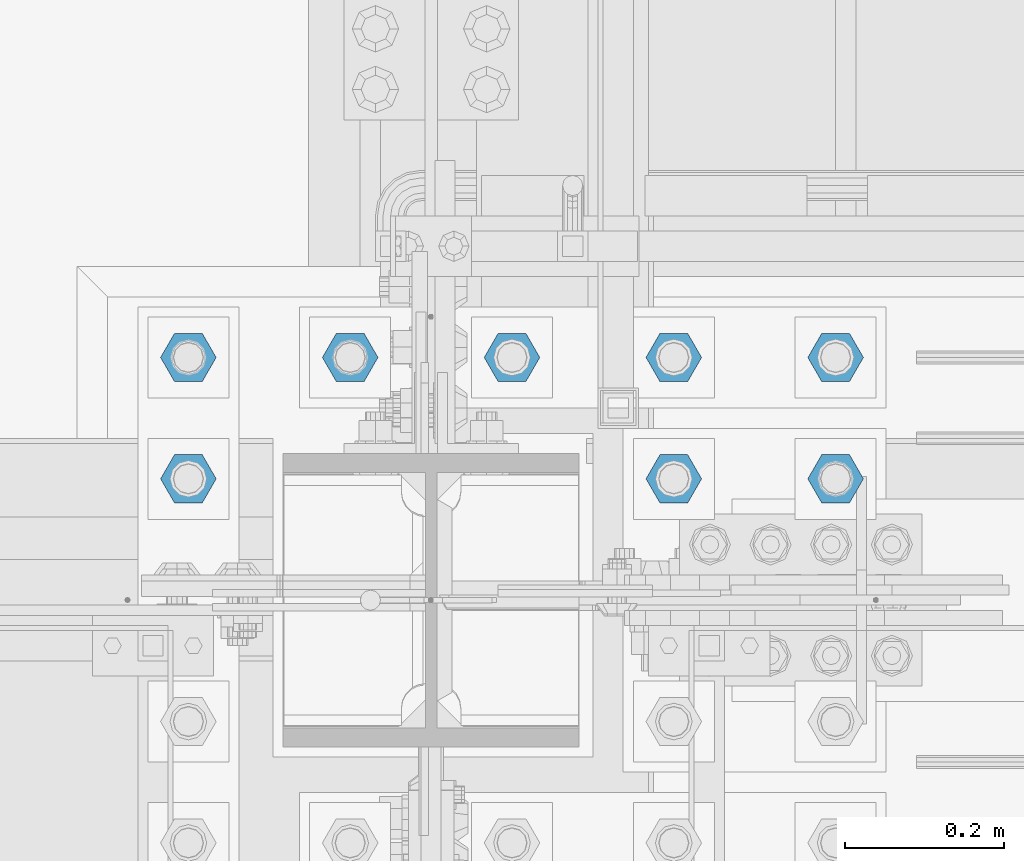
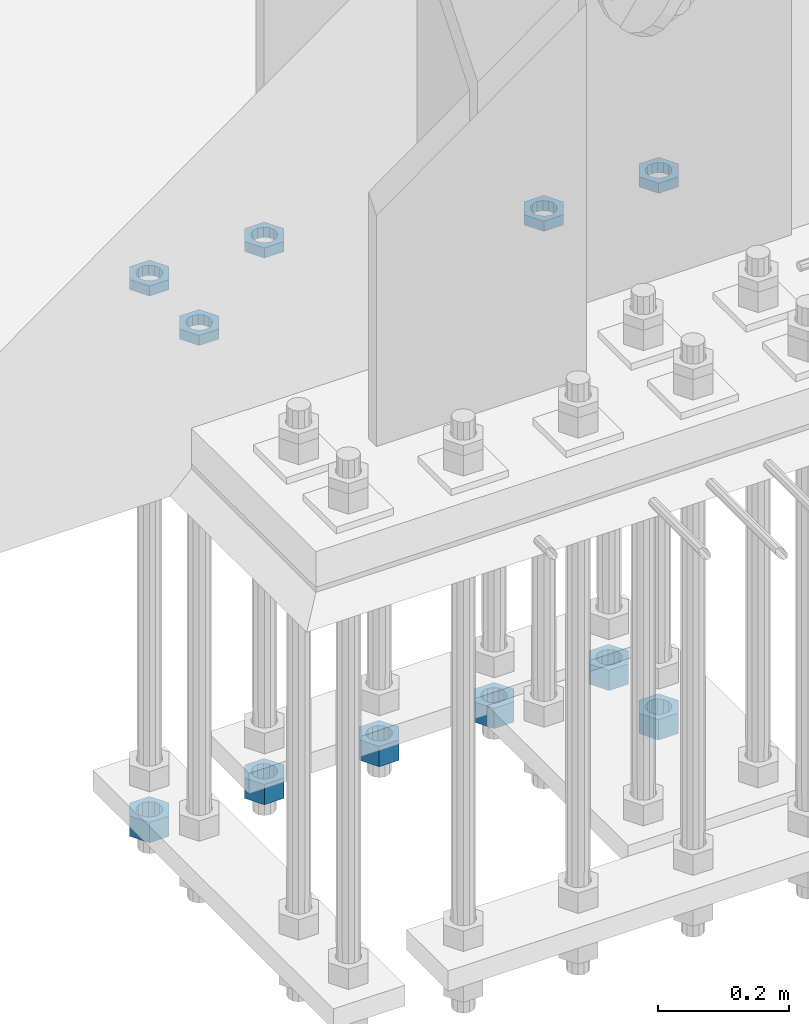
# One storey, part 2828 of 3843: 11 beams, 1 element without a shape of its own.
"""IFC2X3 building model written with IfcOpenShell, lengths in millimetres."""

from ifc_helpers import new_model, si_unit, frame, origin_with_axes, place, context, subcontext, project, spatial, faceted_brep, material, type_object, element, aggregate, save


model = new_model("IFC2X3")

# Units and contexts
model_context = context("Model", 3, precision=1e-05, world=origin_with_axes())
body_context = subcontext(model_context, "Body", "Model", "MODEL_VIEW")
ifc_project = project(units=[si_unit("LENGTHUNIT", "METRE", prefix="MILLI"), si_unit("AREAUNIT", "SQUARE_METRE"), si_unit("VOLUMEUNIT", "CUBIC_METRE"), si_unit("MASSUNIT", "GRAM", prefix="KILO"), si_unit("TIMEUNIT", "SECOND"), si_unit("PLANEANGLEUNIT", "RADIAN"), si_unit("SOLIDANGLEUNIT", "STERADIAN"), si_unit("THERMODYNAMICTEMPERATUREUNIT", "DEGREE_CELSIUS"), si_unit("LUMINOUSINTENSITYUNIT", "LUMEN")], contexts=[model_context])

# Site, building, storey
site_placement = place(None, origin_with_axes())
site = spatial("IfcSite", under=ifc_project, at=site_placement, CompositionType="ELEMENT")
building_placement = place(site_placement, origin_with_axes())
building = spatial("IfcBuilding", under=site, at=building_placement, Name="Undefined", CompositionType="ELEMENT")
storey_placement = place(building_placement, origin_with_axes())
storey = spatial("IfcBuildingStorey", under=building, at=storey_placement, Name="Undefined", CompositionType="ELEMENT", Elevation=0.0)

# Assembly, beams
assembly_placement = place(storey_placement, origin_with_axes())
assembly = element("IfcElementAssembly", 1, at=assembly_placement, inside=storey, Name="TEMPLATE", AssemblyPlace="NOTDEFINED", PredefinedType="RIGID_FRAME")
ifc_material = material(Name="STEEL/A572-50")
beam_type_1 = type_object("IfcBeamType", Name="1-1/2_HEAVY_HEX_NUT", PredefinedType="NOTDEFINED")
beam_1_placement = place(assembly_placement, frame((56438.8, 25768.3, 28746.4500015259), z_axis=(0.0, 1.0, 0.0), x_axis=(0.0, 0.0, -1.0)))
beam_1 = element("IfcBeam", 2, at=beam_1_placement, type_object=beam_type_1, material=ifc_material, Name="NUT", ObjectType="1-1/2_HEAVY_HEX_NUT", context=body_context, shape_type="Brep", body=[
    faceted_brep([(0.0, -34.9199981689453, 0.0), (0.0, -17.4599990844727, -30.25), (38.0999999999985, -17.4599990844727, -30.25), (38.0999999999985, -34.9199981689453, 0.0), (0.0, 17.4599990844727, -30.25), (38.0999999999985, 17.4599990844727, -30.25), (0.0, 34.9199981689453, 0.0), (38.0999999999985, 34.9199981689453, 0.0), (0.0, 17.4599990844727, 30.25), (38.0999999999985, 17.4599990844727, 30.25), (0.0, -17.4599990844727, 30.25), (38.0999999999985, -17.4599990844727, 30.25), (0.0, 0.0, 20.6399993896484), (0.0, 8.9553601105581, 18.5959968835959), (38.0999999999985, 8.9553601105581, 18.5959968835959), (38.0999999999985, 0.0, 20.6399993896484), (0.0, 16.1370013209525, 12.8688291298167), (38.0999999999985, 16.1370013209525, 12.8688291298167), (0.0, 20.1225115123816, 4.59283194104501), (38.0999999999985, 20.1225115123816, 4.59283194104501), (0.0, 20.1225115123816, -4.59283194104501), (38.0999999999985, 20.1225115123816, -4.59283194104501), (0.0, 16.1370013209525, -12.8688291298167), (38.0999999999985, 16.1370013209525, -12.8688291298167), (0.0, 8.9553601105581, -18.5959968835959), (38.0999999999985, 8.9553601105581, -18.5959968835959), (0.0, 0.0, -20.6399993896484), (38.0999999999985, 0.0, -20.6399993896484), (0.0, -8.9553601105581, -18.5959968835959), (38.0999999999985, -8.9553601105581, -18.5959968835959), (0.0, -16.1370013209525, -12.8688291298167), (38.0999999999985, -16.1370013209525, -12.8688291298167), (0.0, -20.1225115123816, -4.59283194104501), (38.0999999999985, -20.1225115123816, -4.59283194104501), (0.0, -20.1225115123816, 4.59283194104501), (38.0999999999985, -20.1225115123816, 4.59283194104501), (0.0, -16.1370013209525, 12.8688291298167), (38.0999999999985, -16.1370013209525, 12.8688291298167), (0.0, -8.9553601105581, 18.5959968835959), (38.0999999999985, -8.9553601105581, 18.5959968835959)], [[[0, 1, 2, 3]], [[1, 4, 5, 2]], [[4, 6, 7, 5]], [[6, 8, 9, 7]], [[8, 10, 11, 9]], [[10, 0, 3, 11]], [[12, 13, 14, 15]], [[13, 16, 17, 14]], [[16, 18, 19, 17]], [[18, 20, 21, 19]], [[20, 22, 23, 21]], [[22, 24, 25, 23]], [[24, 26, 27, 25]], [[26, 28, 29, 27]], [[28, 30, 31, 29]], [[30, 32, 33, 31]], [[32, 34, 35, 33]], [[34, 36, 37, 35]], [[36, 38, 39, 37]], [[38, 12, 15, 39]], [[5, 7, 9, 11, 3, 2], [17, 19, 21, 23, 25, 27, 29, 31, 33, 35, 37, 39, 15, 14]], [[10, 8, 6, 4, 1, 0], [38, 36, 34, 32, 30, 28, 26, 24, 22, 20, 18, 16, 13, 12]]]),
])
beam_2_placement = place(assembly_placement, frame((55626.0, 25920.7, 28746.4500015259), z_axis=(0.0, -1.0, 0.0), x_axis=(0.0, 0.0, -1.0)))
beam_2 = element("IfcBeam", 3, at=beam_2_placement, type_object=beam_type_1, material=ifc_material, Name="NUT", ObjectType="1-1/2_HEAVY_HEX_NUT", context=body_context, shape_type="Brep", body=[
    faceted_brep([(0.0, -34.9199981689453, 0.0), (0.0, -17.4599990844727, -30.25), (38.0999999999985, -17.4599990844727, -30.25), (38.0999999999985, -34.9199981689453, 0.0), (0.0, 17.4599990844727, -30.25), (38.0999999999985, 17.4599990844727, -30.25), (0.0, 34.9199981689453, 0.0), (38.0999999999985, 34.9199981689453, 0.0), (0.0, 17.4599990844727, 30.25), (38.0999999999985, 17.4599990844727, 30.25), (0.0, -17.4599990844727, 30.25), (38.0999999999985, -17.4599990844727, 30.25), (0.0, 0.0, 20.6399993896484), (0.0, 8.9553601105581, 18.5959968835959), (38.0999999999985, 8.9553601105581, 18.5959968835959), (38.0999999999985, 0.0, 20.6399993896484), (0.0, 16.1370013209525, 12.8688291298167), (38.0999999999985, 16.1370013209525, 12.8688291298167), (0.0, 20.1225115123816, 4.59283194104501), (38.0999999999985, 20.1225115123816, 4.59283194104501), (0.0, 20.1225115123816, -4.59283194104501), (38.0999999999985, 20.1225115123816, -4.59283194104501), (0.0, 16.1370013209525, -12.8688291298167), (38.0999999999985, 16.1370013209525, -12.8688291298167), (0.0, 8.9553601105581, -18.5959968835959), (38.0999999999985, 8.9553601105581, -18.5959968835959), (0.0, 0.0, -20.6399993896484), (38.0999999999985, 0.0, -20.6399993896484), (0.0, -8.9553601105581, -18.5959968835959), (38.0999999999985, -8.9553601105581, -18.5959968835959), (0.0, -16.1370013209525, -12.8688291298167), (38.0999999999985, -16.1370013209525, -12.8688291298167), (0.0, -20.1225115123816, -4.59283194104501), (38.0999999999985, -20.1225115123816, -4.59283194104501), (0.0, -20.1225115123816, 4.59283194104501), (38.0999999999985, -20.1225115123816, 4.59283194104501), (0.0, -16.1370013209525, 12.8688291298167), (38.0999999999985, -16.1370013209525, 12.8688291298167), (0.0, -8.9553601105581, 18.5959968835959), (38.0999999999985, -8.9553601105581, 18.5959968835959)], [[[0, 1, 2, 3]], [[1, 4, 5, 2]], [[4, 6, 7, 5]], [[6, 8, 9, 7]], [[8, 10, 11, 9]], [[10, 0, 3, 11]], [[12, 13, 14, 15]], [[13, 16, 17, 14]], [[16, 18, 19, 17]], [[18, 20, 21, 19]], [[20, 22, 23, 21]], [[22, 24, 25, 23]], [[24, 26, 27, 25]], [[26, 28, 29, 27]], [[28, 30, 31, 29]], [[30, 32, 33, 31]], [[32, 34, 35, 33]], [[34, 36, 37, 35]], [[36, 38, 39, 37]], [[38, 12, 15, 39]], [[5, 7, 9, 11, 3, 2], [17, 19, 21, 23, 25, 27, 29, 31, 33, 35, 37, 39, 15, 14]], [[10, 8, 6, 4, 1, 0], [38, 36, 34, 32, 30, 28, 26, 24, 22, 20, 18, 16, 13, 12]]]),
])
beam_3_placement = place(assembly_placement, frame((55829.2, 25920.7, 28746.4500015259), z_axis=(0.0, -1.0, 0.0), x_axis=(0.0, 0.0, -1.0)))
beam_3 = element("IfcBeam", 4, at=beam_3_placement, type_object=beam_type_1, material=ifc_material, Name="NUT", ObjectType="1-1/2_HEAVY_HEX_NUT", context=body_context, shape_type="Brep", body=[
    faceted_brep([(0.0, -34.9199981689453, 0.0), (0.0, -17.4599990844727, -30.25), (38.0999999999985, -17.4599990844727, -30.25), (38.0999999999985, -34.9199981689453, 0.0), (0.0, 17.4599990844727, -30.25), (38.0999999999985, 17.4599990844727, -30.25), (0.0, 34.9199981689453, 0.0), (38.0999999999985, 34.9199981689453, 0.0), (0.0, 17.4599990844727, 30.25), (38.0999999999985, 17.4599990844727, 30.25), (0.0, -17.4599990844727, 30.25), (38.0999999999985, -17.4599990844727, 30.25), (0.0, 0.0, 20.6399993896484), (0.0, 8.9553601105581, 18.5959968835959), (38.0999999999985, 8.9553601105581, 18.5959968835959), (38.0999999999985, 0.0, 20.6399993896484), (0.0, 16.1370013209525, 12.8688291298167), (38.0999999999985, 16.1370013209525, 12.8688291298167), (0.0, 20.1225115123816, 4.59283194104501), (38.0999999999985, 20.1225115123816, 4.59283194104501), (0.0, 20.1225115123816, -4.59283194104501), (38.0999999999985, 20.1225115123816, -4.59283194104501), (0.0, 16.1370013209525, -12.8688291298167), (38.0999999999985, 16.1370013209525, -12.8688291298167), (0.0, 8.9553601105581, -18.5959968835959), (38.0999999999985, 8.9553601105581, -18.5959968835959), (0.0, 0.0, -20.6399993896484), (38.0999999999985, 0.0, -20.6399993896484), (0.0, -8.9553601105581, -18.5959968835959), (38.0999999999985, -8.9553601105581, -18.5959968835959), (0.0, -16.1370013209525, -12.8688291298167), (38.0999999999985, -16.1370013209525, -12.8688291298167), (0.0, -20.1225115123816, -4.59283194104501), (38.0999999999985, -20.1225115123816, -4.59283194104501), (0.0, -20.1225115123816, 4.59283194104501), (38.0999999999985, -20.1225115123816, 4.59283194104501), (0.0, -16.1370013209525, 12.8688291298167), (38.0999999999985, -16.1370013209525, 12.8688291298167), (0.0, -8.9553601105581, 18.5959968835959), (38.0999999999985, -8.9553601105581, 18.5959968835959)], [[[0, 1, 2, 3]], [[1, 4, 5, 2]], [[4, 6, 7, 5]], [[6, 8, 9, 7]], [[8, 10, 11, 9]], [[10, 0, 3, 11]], [[12, 13, 14, 15]], [[13, 16, 17, 14]], [[16, 18, 19, 17]], [[18, 20, 21, 19]], [[20, 22, 23, 21]], [[22, 24, 25, 23]], [[24, 26, 27, 25]], [[26, 28, 29, 27]], [[28, 30, 31, 29]], [[30, 32, 33, 31]], [[32, 34, 35, 33]], [[34, 36, 37, 35]], [[36, 38, 39, 37]], [[38, 12, 15, 39]], [[5, 7, 9, 11, 3, 2], [17, 19, 21, 23, 25, 27, 29, 31, 33, 35, 37, 39, 15, 14]], [[10, 8, 6, 4, 1, 0], [38, 36, 34, 32, 30, 28, 26, 24, 22, 20, 18, 16, 13, 12]]]),
])
beam_4_placement = place(assembly_placement, frame((56032.4, 25920.7, 28746.4500015259), z_axis=(0.0, -1.0, 0.0), x_axis=(0.0, 0.0, -1.0)))
beam_4 = element("IfcBeam", 5, at=beam_4_placement, type_object=beam_type_1, material=ifc_material, Name="NUT", ObjectType="1-1/2_HEAVY_HEX_NUT", context=body_context, shape_type="Brep", body=[
    faceted_brep([(0.0, -34.9199981689453, 0.0), (0.0, -17.4599990844727, -30.25), (38.0999999999985, -17.4599990844727, -30.25), (38.0999999999985, -34.9199981689453, 0.0), (0.0, 17.4599990844727, -30.25), (38.0999999999985, 17.4599990844727, -30.25), (0.0, 34.9199981689453, 0.0), (38.0999999999985, 34.9199981689453, 0.0), (0.0, 17.4599990844727, 30.25), (38.0999999999985, 17.4599990844727, 30.25), (0.0, -17.4599990844727, 30.25), (38.0999999999985, -17.4599990844727, 30.25), (0.0, 0.0, 20.6399993896484), (0.0, 8.9553601105581, 18.5959968835959), (38.0999999999985, 8.9553601105581, 18.5959968835959), (38.0999999999985, 0.0, 20.6399993896484), (0.0, 16.1370013209525, 12.8688291298167), (38.0999999999985, 16.1370013209525, 12.8688291298167), (0.0, 20.1225115123816, 4.59283194104501), (38.0999999999985, 20.1225115123816, 4.59283194104501), (0.0, 20.1225115123816, -4.59283194104501), (38.0999999999985, 20.1225115123816, -4.59283194104501), (0.0, 16.1370013209525, -12.8688291298167), (38.0999999999985, 16.1370013209525, -12.8688291298167), (0.0, 8.9553601105581, -18.5959968835959), (38.0999999999985, 8.9553601105581, -18.5959968835959), (0.0, 0.0, -20.6399993896484), (38.0999999999985, 0.0, -20.6399993896484), (0.0, -8.9553601105581, -18.5959968835959), (38.0999999999985, -8.9553601105581, -18.5959968835959), (0.0, -16.1370013209525, -12.8688291298167), (38.0999999999985, -16.1370013209525, -12.8688291298167), (0.0, -20.1225115123816, -4.59283194104501), (38.0999999999985, -20.1225115123816, -4.59283194104501), (0.0, -20.1225115123816, 4.59283194104501), (38.0999999999985, -20.1225115123816, 4.59283194104501), (0.0, -16.1370013209525, 12.8688291298167), (38.0999999999985, -16.1370013209525, 12.8688291298167), (0.0, -8.9553601105581, 18.5959968835959), (38.0999999999985, -8.9553601105581, 18.5959968835959)], [[[0, 1, 2, 3]], [[1, 4, 5, 2]], [[4, 6, 7, 5]], [[6, 8, 9, 7]], [[8, 10, 11, 9]], [[10, 0, 3, 11]], [[12, 13, 14, 15]], [[13, 16, 17, 14]], [[16, 18, 19, 17]], [[18, 20, 21, 19]], [[20, 22, 23, 21]], [[22, 24, 25, 23]], [[24, 26, 27, 25]], [[26, 28, 29, 27]], [[28, 30, 31, 29]], [[30, 32, 33, 31]], [[32, 34, 35, 33]], [[34, 36, 37, 35]], [[36, 38, 39, 37]], [[38, 12, 15, 39]], [[5, 7, 9, 11, 3, 2], [17, 19, 21, 23, 25, 27, 29, 31, 33, 35, 37, 39, 15, 14]], [[10, 8, 6, 4, 1, 0], [38, 36, 34, 32, 30, 28, 26, 24, 22, 20, 18, 16, 13, 12]]]),
])
beam_5_placement = place(assembly_placement, frame((56235.6, 25920.7, 28746.4500015259), z_axis=(0.0, 1.0, 0.0), x_axis=(0.0, 0.0, -1.0)))
beam_5 = element("IfcBeam", 6, at=beam_5_placement, type_object=beam_type_1, material=ifc_material, Name="NUT", ObjectType="1-1/2_HEAVY_HEX_NUT", context=body_context, shape_type="Brep", body=[
    faceted_brep([(0.0, -34.9199981689453, 0.0), (0.0, -17.4599990844727, -30.25), (38.0999999999985, -17.4599990844727, -30.25), (38.0999999999985, -34.9199981689453, 0.0), (0.0, 17.4599990844727, -30.25), (38.0999999999985, 17.4599990844727, -30.25), (0.0, 34.9199981689453, 0.0), (38.0999999999985, 34.9199981689453, 0.0), (0.0, 17.4599990844727, 30.25), (38.0999999999985, 17.4599990844727, 30.25), (0.0, -17.4599990844727, 30.25), (38.0999999999985, -17.4599990844727, 30.25), (0.0, 0.0, 20.6399993896484), (0.0, 8.9553601105581, 18.5959968835959), (38.0999999999985, 8.9553601105581, 18.5959968835959), (38.0999999999985, 0.0, 20.6399993896484), (0.0, 16.1370013209525, 12.8688291298167), (38.0999999999985, 16.1370013209525, 12.8688291298167), (0.0, 20.1225115123816, 4.59283194104501), (38.0999999999985, 20.1225115123816, 4.59283194104501), (0.0, 20.1225115123816, -4.59283194104501), (38.0999999999985, 20.1225115123816, -4.59283194104501), (0.0, 16.1370013209525, -12.8688291298167), (38.0999999999985, 16.1370013209525, -12.8688291298167), (0.0, 8.9553601105581, -18.5959968835959), (38.0999999999985, 8.9553601105581, -18.5959968835959), (0.0, 0.0, -20.6399993896484), (38.0999999999985, 0.0, -20.6399993896484), (0.0, -8.9553601105581, -18.5959968835959), (38.0999999999985, -8.9553601105581, -18.5959968835959), (0.0, -16.1370013209525, -12.8688291298167), (38.0999999999985, -16.1370013209525, -12.8688291298167), (0.0, -20.1225115123816, -4.59283194104501), (38.0999999999985, -20.1225115123816, -4.59283194104501), (0.0, -20.1225115123816, 4.59283194104501), (38.0999999999985, -20.1225115123816, 4.59283194104501), (0.0, -16.1370013209525, 12.8688291298167), (38.0999999999985, -16.1370013209525, 12.8688291298167), (0.0, -8.9553601105581, 18.5959968835959), (38.0999999999985, -8.9553601105581, 18.5959968835959)], [[[0, 1, 2, 3]], [[1, 4, 5, 2]], [[4, 6, 7, 5]], [[6, 8, 9, 7]], [[8, 10, 11, 9]], [[10, 0, 3, 11]], [[12, 13, 14, 15]], [[13, 16, 17, 14]], [[16, 18, 19, 17]], [[18, 20, 21, 19]], [[20, 22, 23, 21]], [[22, 24, 25, 23]], [[24, 26, 27, 25]], [[26, 28, 29, 27]], [[28, 30, 31, 29]], [[30, 32, 33, 31]], [[32, 34, 35, 33]], [[34, 36, 37, 35]], [[36, 38, 39, 37]], [[38, 12, 15, 39]], [[5, 7, 9, 11, 3, 2], [17, 19, 21, 23, 25, 27, 29, 31, 33, 35, 37, 39, 15, 14]], [[10, 8, 6, 4, 1, 0], [38, 36, 34, 32, 30, 28, 26, 24, 22, 20, 18, 16, 13, 12]]]),
])
beam_6_placement = place(assembly_placement, frame((56438.8, 25920.7, 28746.4500015259), z_axis=(0.0, 1.0, 0.0), x_axis=(0.0, 0.0, -1.0)))
beam_6 = element("IfcBeam", 7, at=beam_6_placement, type_object=beam_type_1, material=ifc_material, Name="NUT", ObjectType="1-1/2_HEAVY_HEX_NUT", context=body_context, shape_type="Brep", body=[
    faceted_brep([(0.0, -34.9199981689453, 0.0), (0.0, -17.4599990844727, -30.25), (38.0999999999985, -17.4599990844727, -30.25), (38.0999999999985, -34.9199981689453, 0.0), (0.0, 17.4599990844727, -30.25), (38.0999999999985, 17.4599990844727, -30.25), (0.0, 34.9199981689453, 0.0), (38.0999999999985, 34.9199981689453, 0.0), (0.0, 17.4599990844727, 30.25), (38.0999999999985, 17.4599990844727, 30.25), (0.0, -17.4599990844727, 30.25), (38.0999999999985, -17.4599990844727, 30.25), (0.0, 0.0, 20.6399993896484), (0.0, 8.9553601105581, 18.5959968835959), (38.0999999999985, 8.9553601105581, 18.5959968835959), (38.0999999999985, 0.0, 20.6399993896484), (0.0, 16.1370013209525, 12.8688291298167), (38.0999999999985, 16.1370013209525, 12.8688291298167), (0.0, 20.1225115123816, 4.59283194104501), (38.0999999999985, 20.1225115123816, 4.59283194104501), (0.0, 20.1225115123816, -4.59283194104501), (38.0999999999985, 20.1225115123816, -4.59283194104501), (0.0, 16.1370013209525, -12.8688291298167), (38.0999999999985, 16.1370013209525, -12.8688291298167), (0.0, 8.9553601105581, -18.5959968835959), (38.0999999999985, 8.9553601105581, -18.5959968835959), (0.0, 0.0, -20.6399993896484), (38.0999999999985, 0.0, -20.6399993896484), (0.0, -8.9553601105581, -18.5959968835959), (38.0999999999985, -8.9553601105581, -18.5959968835959), (0.0, -16.1370013209525, -12.8688291298167), (38.0999999999985, -16.1370013209525, -12.8688291298167), (0.0, -20.1225115123816, -4.59283194104501), (38.0999999999985, -20.1225115123816, -4.59283194104501), (0.0, -20.1225115123816, 4.59283194104501), (38.0999999999985, -20.1225115123816, 4.59283194104501), (0.0, -16.1370013209525, 12.8688291298167), (38.0999999999985, -16.1370013209525, 12.8688291298167), (0.0, -8.9553601105581, 18.5959968835959), (38.0999999999985, -8.9553601105581, 18.5959968835959)], [[[0, 1, 2, 3]], [[1, 4, 5, 2]], [[4, 6, 7, 5]], [[6, 8, 9, 7]], [[8, 10, 11, 9]], [[10, 0, 3, 11]], [[12, 13, 14, 15]], [[13, 16, 17, 14]], [[16, 18, 19, 17]], [[18, 20, 21, 19]], [[20, 22, 23, 21]], [[22, 24, 25, 23]], [[24, 26, 27, 25]], [[26, 28, 29, 27]], [[28, 30, 31, 29]], [[30, 32, 33, 31]], [[32, 34, 35, 33]], [[34, 36, 37, 35]], [[36, 38, 39, 37]], [[38, 12, 15, 39]], [[5, 7, 9, 11, 3, 2], [17, 19, 21, 23, 25, 27, 29, 31, 33, 35, 37, 39, 15, 14]], [[10, 8, 6, 4, 1, 0], [38, 36, 34, 32, 30, 28, 26, 24, 22, 20, 18, 16, 13, 12]]]),
])
beam_type_2 = type_object("IfcBeamType", Name="1-1/2_HALF_NUT", PredefinedType="NOTDEFINED")
beam_7_placement = place(assembly_placement, frame((55626.0, 25768.3, 29749.75), z_axis=(0.0, -1.0, 0.0), x_axis=(0.0, 0.0, -1.0)))
beam_7 = element("IfcBeam", 8, at=beam_7_placement, type_object=beam_type_2, material=ifc_material, Name="NUT", ObjectType="1-1/2_HALF_NUT", context=body_context, shape_type="Brep", body=[
    faceted_brep([(0.0, -34.9199981689453, 0.0), (0.0, -17.4599990844727, -30.25), (19.0500000000029, -17.4599990844727, -30.25), (19.0500000000029, -34.9199981689453, 0.0), (0.0, 17.4599990844727, -30.25), (19.0500000000029, 17.4599990844727, -30.25), (0.0, 34.9199981689453, 0.0), (19.0500000000029, 34.9199981689453, 0.0), (0.0, 17.4599990844727, 30.25), (19.0500000000029, 17.4599990844727, 30.25), (0.0, -17.4599990844727, 30.25), (19.0500000000029, -17.4599990844727, 30.25), (0.0, 0.0, 20.6399993896484), (0.0, 8.9553601105581, 18.5959968835959), (19.0500000000029, 8.95536011056538, 18.5959968835959), (19.0500000000029, 0.0, 20.6399993896484), (0.0, 16.1370013209525, 12.8688291298167), (19.0500000000029, 16.1370013209489, 12.8688291298167), (0.0, 20.1225115123816, 4.59283194104501), (19.0500000000029, 20.1225115123852, 4.59283194104501), (0.0, 20.1225115123816, -4.59283194104501), (19.0500000000029, 20.1225115123852, -4.59283194104501), (0.0, 16.1370013209525, -12.8688291298167), (19.0500000000029, 16.1370013209489, -12.8688291298167), (0.0, 8.9553601105581, -18.5959968835959), (19.0500000000029, 8.95536011056538, -18.5959968835959), (0.0, 0.0, -20.6399993896484), (19.0500000000029, 0.0, -20.6399993896484), (0.0, -8.9553601105581, -18.5959968835959), (19.0500000000029, -8.95536011056538, -18.5959968835959), (0.0, -16.1370013209525, -12.8688291298167), (19.0500000000029, -16.1370013209489, -12.8688291298167), (0.0, -20.1225115123816, -4.59283194104501), (19.0500000000029, -20.1225115123852, -4.59283194104501), (0.0, -20.1225115123816, 4.59283194104501), (19.0500000000029, -20.1225115123852, 4.59283194104501), (0.0, -16.1370013209525, 12.8688291298167), (19.0500000000029, -16.1370013209489, 12.8688291298167), (0.0, -8.9553601105581, 18.5959968835959), (19.0500000000029, -8.95536011056538, 18.5959968835959)], [[[0, 1, 2, 3]], [[1, 4, 5, 2]], [[4, 6, 7, 5]], [[6, 8, 9, 7]], [[8, 10, 11, 9]], [[10, 0, 3, 11]], [[12, 13, 14, 15]], [[13, 16, 17, 14]], [[16, 18, 19, 17]], [[18, 20, 21, 19]], [[20, 22, 23, 21]], [[22, 24, 25, 23]], [[24, 26, 27, 25]], [[26, 28, 29, 27]], [[28, 30, 31, 29]], [[30, 32, 33, 31]], [[32, 34, 35, 33]], [[34, 36, 37, 35]], [[36, 38, 39, 37]], [[38, 12, 15, 39]], [[5, 7, 9, 11, 3, 2], [17, 19, 21, 23, 25, 27, 29, 31, 33, 35, 37, 39, 15, 14]], [[10, 8, 6, 4, 1, 0], [38, 36, 34, 32, 30, 28, 26, 24, 22, 20, 18, 16, 13, 12]]]),
])
beam_8_placement = place(assembly_placement, frame((56235.6, 25768.3, 29749.75), z_axis=(0.0, 1.0, 0.0), x_axis=(0.0, 0.0, -1.0)))
beam_8 = element("IfcBeam", 9, at=beam_8_placement, type_object=beam_type_2, material=ifc_material, Name="NUT", ObjectType="1-1/2_HALF_NUT", context=body_context, shape_type="Brep", body=[
    faceted_brep([(0.0, -34.9199981689453, 0.0), (0.0, -17.4599990844727, -30.25), (19.0500000000029, -17.4599990844727, -30.25), (19.0500000000029, -34.9199981689453, 0.0), (0.0, 17.4599990844727, -30.25), (19.0500000000029, 17.4599990844727, -30.25), (0.0, 34.9199981689453, 0.0), (19.0500000000029, 34.9199981689453, 0.0), (0.0, 17.4599990844727, 30.25), (19.0500000000029, 17.4599990844727, 30.25), (0.0, -17.4599990844727, 30.25), (19.0500000000029, -17.4599990844727, 30.25), (0.0, 0.0, 20.6399993896484), (0.0, 8.9553601105581, 18.5959968835959), (19.0500000000029, 8.95536011056538, 18.5959968835959), (19.0500000000029, 0.0, 20.6399993896484), (0.0, 16.1370013209525, 12.8688291298167), (19.0500000000029, 16.1370013209489, 12.8688291298167), (0.0, 20.1225115123816, 4.59283194104501), (19.0500000000029, 20.1225115123852, 4.59283194104501), (0.0, 20.1225115123816, -4.59283194104501), (19.0500000000029, 20.1225115123852, -4.59283194104501), (0.0, 16.1370013209525, -12.8688291298167), (19.0500000000029, 16.1370013209489, -12.8688291298167), (0.0, 8.9553601105581, -18.5959968835959), (19.0500000000029, 8.95536011056538, -18.5959968835959), (0.0, 0.0, -20.6399993896484), (19.0500000000029, 0.0, -20.6399993896484), (0.0, -8.9553601105581, -18.5959968835959), (19.0500000000029, -8.95536011056538, -18.5959968835959), (0.0, -16.1370013209525, -12.8688291298167), (19.0500000000029, -16.1370013209489, -12.8688291298167), (0.0, -20.1225115123816, -4.59283194104501), (19.0500000000029, -20.1225115123852, -4.59283194104501), (0.0, -20.1225115123816, 4.59283194104501), (19.0500000000029, -20.1225115123852, 4.59283194104501), (0.0, -16.1370013209525, 12.8688291298167), (19.0500000000029, -16.1370013209489, 12.8688291298167), (0.0, -8.9553601105581, 18.5959968835959), (19.0500000000029, -8.95536011056538, 18.5959968835959)], [[[0, 1, 2, 3]], [[1, 4, 5, 2]], [[4, 6, 7, 5]], [[6, 8, 9, 7]], [[8, 10, 11, 9]], [[10, 0, 3, 11]], [[12, 13, 14, 15]], [[13, 16, 17, 14]], [[16, 18, 19, 17]], [[18, 20, 21, 19]], [[20, 22, 23, 21]], [[22, 24, 25, 23]], [[24, 26, 27, 25]], [[26, 28, 29, 27]], [[28, 30, 31, 29]], [[30, 32, 33, 31]], [[32, 34, 35, 33]], [[34, 36, 37, 35]], [[36, 38, 39, 37]], [[38, 12, 15, 39]], [[5, 7, 9, 11, 3, 2], [17, 19, 21, 23, 25, 27, 29, 31, 33, 35, 37, 39, 15, 14]], [[10, 8, 6, 4, 1, 0], [38, 36, 34, 32, 30, 28, 26, 24, 22, 20, 18, 16, 13, 12]]]),
])
beam_9_placement = place(assembly_placement, frame((56438.8, 25768.3, 29749.75), z_axis=(0.0, 1.0, 0.0), x_axis=(0.0, 0.0, -1.0)))
beam_9 = element("IfcBeam", 10, at=beam_9_placement, type_object=beam_type_2, material=ifc_material, Name="NUT", ObjectType="1-1/2_HALF_NUT", context=body_context, shape_type="Brep", body=[
    faceted_brep([(0.0, -34.9199981689453, 0.0), (0.0, -17.4599990844727, -30.25), (19.0500000000029, -17.4599990844727, -30.25), (19.0500000000029, -34.9199981689453, 0.0), (0.0, 17.4599990844727, -30.25), (19.0500000000029, 17.4599990844727, -30.25), (0.0, 34.9199981689453, 0.0), (19.0500000000029, 34.9199981689453, 0.0), (0.0, 17.4599990844727, 30.25), (19.0500000000029, 17.4599990844727, 30.25), (0.0, -17.4599990844727, 30.25), (19.0500000000029, -17.4599990844727, 30.25), (0.0, 0.0, 20.6399993896484), (0.0, 8.9553601105581, 18.5959968835959), (19.0500000000029, 8.95536011056538, 18.5959968835959), (19.0500000000029, 0.0, 20.6399993896484), (0.0, 16.1370013209525, 12.8688291298167), (19.0500000000029, 16.1370013209489, 12.8688291298167), (0.0, 20.1225115123816, 4.59283194104501), (19.0500000000029, 20.1225115123852, 4.59283194104501), (0.0, 20.1225115123816, -4.59283194104501), (19.0500000000029, 20.1225115123852, -4.59283194104501), (0.0, 16.1370013209525, -12.8688291298167), (19.0500000000029, 16.1370013209489, -12.8688291298167), (0.0, 8.9553601105581, -18.5959968835959), (19.0500000000029, 8.95536011056538, -18.5959968835959), (0.0, 0.0, -20.6399993896484), (19.0500000000029, 0.0, -20.6399993896484), (0.0, -8.9553601105581, -18.5959968835959), (19.0500000000029, -8.95536011056538, -18.5959968835959), (0.0, -16.1370013209525, -12.8688291298167), (19.0500000000029, -16.1370013209489, -12.8688291298167), (0.0, -20.1225115123816, -4.59283194104501), (19.0500000000029, -20.1225115123852, -4.59283194104501), (0.0, -20.1225115123816, 4.59283194104501), (19.0500000000029, -20.1225115123852, 4.59283194104501), (0.0, -16.1370013209525, 12.8688291298167), (19.0500000000029, -16.1370013209489, 12.8688291298167), (0.0, -8.9553601105581, 18.5959968835959), (19.0500000000029, -8.95536011056538, 18.5959968835959)], [[[0, 1, 2, 3]], [[1, 4, 5, 2]], [[4, 6, 7, 5]], [[6, 8, 9, 7]], [[8, 10, 11, 9]], [[10, 0, 3, 11]], [[12, 13, 14, 15]], [[13, 16, 17, 14]], [[16, 18, 19, 17]], [[18, 20, 21, 19]], [[20, 22, 23, 21]], [[22, 24, 25, 23]], [[24, 26, 27, 25]], [[26, 28, 29, 27]], [[28, 30, 31, 29]], [[30, 32, 33, 31]], [[32, 34, 35, 33]], [[34, 36, 37, 35]], [[36, 38, 39, 37]], [[38, 12, 15, 39]], [[5, 7, 9, 11, 3, 2], [17, 19, 21, 23, 25, 27, 29, 31, 33, 35, 37, 39, 15, 14]], [[10, 8, 6, 4, 1, 0], [38, 36, 34, 32, 30, 28, 26, 24, 22, 20, 18, 16, 13, 12]]]),
])
beam_10_placement = place(assembly_placement, frame((55626.0, 25920.7, 29749.75), z_axis=(0.0, -1.0, 0.0), x_axis=(0.0, 0.0, -1.0)))
beam_10 = element("IfcBeam", 11, at=beam_10_placement, type_object=beam_type_2, material=ifc_material, Name="NUT", ObjectType="1-1/2_HALF_NUT", context=body_context, shape_type="Brep", body=[
    faceted_brep([(0.0, -34.9199981689453, 0.0), (0.0, -17.4599990844727, -30.25), (19.0500000000029, -17.4599990844727, -30.25), (19.0500000000029, -34.9199981689453, 0.0), (0.0, 17.4599990844727, -30.25), (19.0500000000029, 17.4599990844727, -30.25), (0.0, 34.9199981689453, 0.0), (19.0500000000029, 34.9199981689453, 0.0), (0.0, 17.4599990844727, 30.25), (19.0500000000029, 17.4599990844727, 30.25), (0.0, -17.4599990844727, 30.25), (19.0500000000029, -17.4599990844727, 30.25), (0.0, 0.0, 20.6399993896484), (0.0, 8.9553601105581, 18.5959968835959), (19.0500000000029, 8.95536011056538, 18.5959968835959), (19.0500000000029, 0.0, 20.6399993896484), (0.0, 16.1370013209525, 12.8688291298167), (19.0500000000029, 16.1370013209489, 12.8688291298167), (0.0, 20.1225115123816, 4.59283194104501), (19.0500000000029, 20.1225115123852, 4.59283194104501), (0.0, 20.1225115123816, -4.59283194104501), (19.0500000000029, 20.1225115123852, -4.59283194104501), (0.0, 16.1370013209525, -12.8688291298167), (19.0500000000029, 16.1370013209489, -12.8688291298167), (0.0, 8.9553601105581, -18.5959968835959), (19.0500000000029, 8.95536011056538, -18.5959968835959), (0.0, 0.0, -20.6399993896484), (19.0500000000029, 0.0, -20.6399993896484), (0.0, -8.9553601105581, -18.5959968835959), (19.0500000000029, -8.95536011056538, -18.5959968835959), (0.0, -16.1370013209525, -12.8688291298167), (19.0500000000029, -16.1370013209489, -12.8688291298167), (0.0, -20.1225115123816, -4.59283194104501), (19.0500000000029, -20.1225115123852, -4.59283194104501), (0.0, -20.1225115123816, 4.59283194104501), (19.0500000000029, -20.1225115123852, 4.59283194104501), (0.0, -16.1370013209525, 12.8688291298167), (19.0500000000029, -16.1370013209489, 12.8688291298167), (0.0, -8.9553601105581, 18.5959968835959), (19.0500000000029, -8.95536011056538, 18.5959968835959)], [[[0, 1, 2, 3]], [[1, 4, 5, 2]], [[4, 6, 7, 5]], [[6, 8, 9, 7]], [[8, 10, 11, 9]], [[10, 0, 3, 11]], [[12, 13, 14, 15]], [[13, 16, 17, 14]], [[16, 18, 19, 17]], [[18, 20, 21, 19]], [[20, 22, 23, 21]], [[22, 24, 25, 23]], [[24, 26, 27, 25]], [[26, 28, 29, 27]], [[28, 30, 31, 29]], [[30, 32, 33, 31]], [[32, 34, 35, 33]], [[34, 36, 37, 35]], [[36, 38, 39, 37]], [[38, 12, 15, 39]], [[5, 7, 9, 11, 3, 2], [17, 19, 21, 23, 25, 27, 29, 31, 33, 35, 37, 39, 15, 14]], [[10, 8, 6, 4, 1, 0], [38, 36, 34, 32, 30, 28, 26, 24, 22, 20, 18, 16, 13, 12]]]),
])
beam_11_placement = place(assembly_placement, frame((55829.2, 25920.7, 29749.75), z_axis=(0.0, -1.0, 0.0), x_axis=(0.0, 0.0, -1.0)))
beam_11 = element("IfcBeam", 12, at=beam_11_placement, type_object=beam_type_2, material=ifc_material, Name="NUT", ObjectType="1-1/2_HALF_NUT", context=body_context, shape_type="Brep", body=[
    faceted_brep([(0.0, -34.9199981689453, 0.0), (0.0, -17.4599990844727, -30.25), (19.0500000000029, -17.4599990844727, -30.25), (19.0500000000029, -34.9199981689453, 0.0), (0.0, 17.4599990844727, -30.25), (19.0500000000029, 17.4599990844727, -30.25), (0.0, 34.9199981689453, 0.0), (19.0500000000029, 34.9199981689453, 0.0), (0.0, 17.4599990844727, 30.25), (19.0500000000029, 17.4599990844727, 30.25), (0.0, -17.4599990844727, 30.25), (19.0500000000029, -17.4599990844727, 30.25), (0.0, 0.0, 20.6399993896484), (0.0, 8.9553601105581, 18.5959968835959), (19.0500000000029, 8.95536011056538, 18.5959968835959), (19.0500000000029, 0.0, 20.6399993896484), (0.0, 16.1370013209525, 12.8688291298167), (19.0500000000029, 16.1370013209489, 12.8688291298167), (0.0, 20.1225115123816, 4.59283194104501), (19.0500000000029, 20.1225115123852, 4.59283194104501), (0.0, 20.1225115123816, -4.59283194104501), (19.0500000000029, 20.1225115123852, -4.59283194104501), (0.0, 16.1370013209525, -12.8688291298167), (19.0500000000029, 16.1370013209489, -12.8688291298167), (0.0, 8.9553601105581, -18.5959968835959), (19.0500000000029, 8.95536011056538, -18.5959968835959), (0.0, 0.0, -20.6399993896484), (19.0500000000029, 0.0, -20.6399993896484), (0.0, -8.9553601105581, -18.5959968835959), (19.0500000000029, -8.95536011056538, -18.5959968835959), (0.0, -16.1370013209525, -12.8688291298167), (19.0500000000029, -16.1370013209489, -12.8688291298167), (0.0, -20.1225115123816, -4.59283194104501), (19.0500000000029, -20.1225115123852, -4.59283194104501), (0.0, -20.1225115123816, 4.59283194104501), (19.0500000000029, -20.1225115123852, 4.59283194104501), (0.0, -16.1370013209525, 12.8688291298167), (19.0500000000029, -16.1370013209489, 12.8688291298167), (0.0, -8.9553601105581, 18.5959968835959), (19.0500000000029, -8.95536011056538, 18.5959968835959)], [[[0, 1, 2, 3]], [[1, 4, 5, 2]], [[4, 6, 7, 5]], [[6, 8, 9, 7]], [[8, 10, 11, 9]], [[10, 0, 3, 11]], [[12, 13, 14, 15]], [[13, 16, 17, 14]], [[16, 18, 19, 17]], [[18, 20, 21, 19]], [[20, 22, 23, 21]], [[22, 24, 25, 23]], [[24, 26, 27, 25]], [[26, 28, 29, 27]], [[28, 30, 31, 29]], [[30, 32, 33, 31]], [[32, 34, 35, 33]], [[34, 36, 37, 35]], [[36, 38, 39, 37]], [[38, 12, 15, 39]], [[5, 7, 9, 11, 3, 2], [17, 19, 21, 23, 25, 27, 29, 31, 33, 35, 37, 39, 15, 14]], [[10, 8, 6, 4, 1, 0], [38, 36, 34, 32, 30, 28, 26, 24, 22, 20, 18, 16, 13, 12]]]),
])
aggregate(assembly, [beam_1, beam_2, beam_3, beam_4, beam_5, beam_6, beam_7, beam_8, beam_9, beam_10, beam_11])

save(model, "model.ifc")
